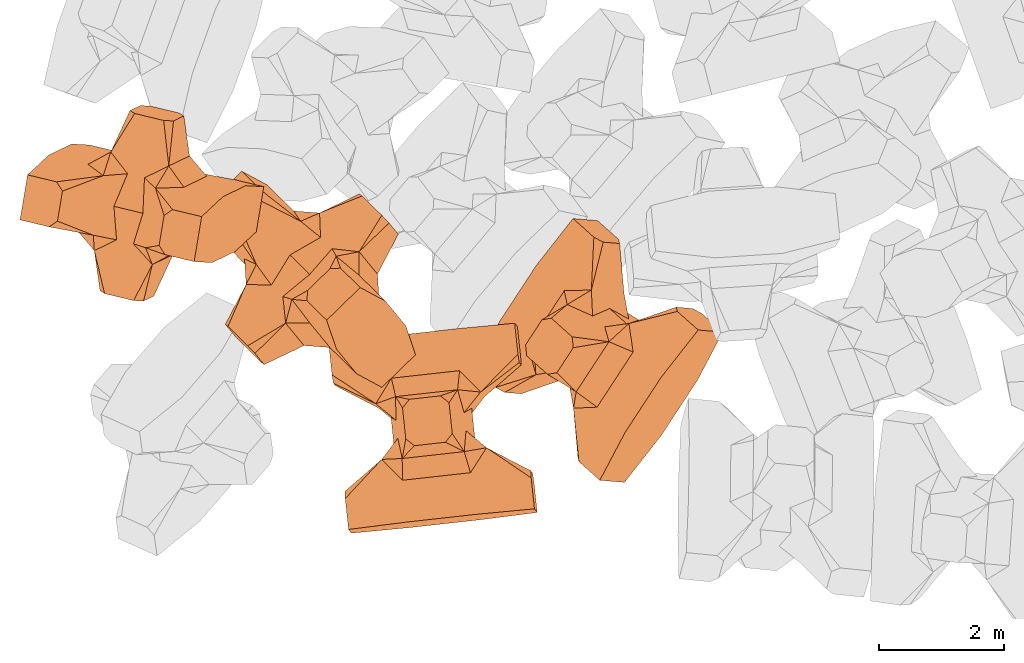
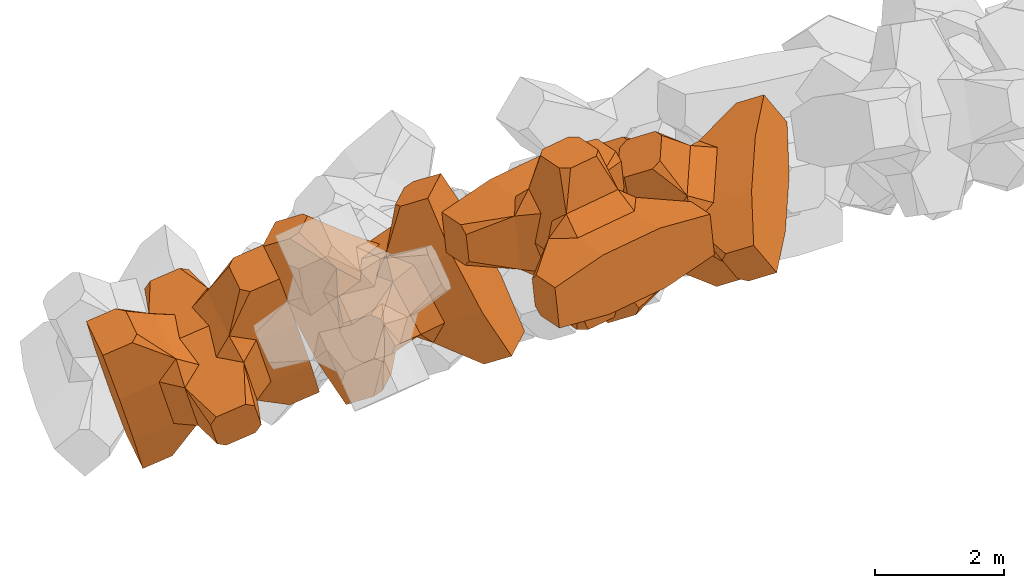
# One storey, part 11 of 17: 4 civil elements.
"""IFC4 building model written with IfcOpenShell, lengths in metres."""

import ifcopenshell
import ifcopenshell.guid

model = None  # the IFC model being written
_history = None  # IfcOwnerHistory: only IFC2X3 demands one
_inside = {}  # id of a spatial element -> (the spatial element, [elements in it])
_under = {}  # id of a project, library or spatial element -> (it, [spatial elements below it])
_declared = {}  # id of a project -> (the project, [libraries it declares])
_typed = {}  # id of a type object -> (the type object, [elements of that type])
_made_of = {}  # id of a material, layer set ... -> (it, [elements and type objects made of it])


def new_model(schema):
    """Start an empty IFC model of exactly this schema.

    Asked for "IFC4X3", IfcOpenShell would pick the latest addendum, in which some entities
    have other attributes; the version numbers below select the first issue.
    IFC2X3 requires an IfcOwnerHistory on every rooted entity: one is made here for all.
    """
    global model, _history
    if schema == "IFC4X3":
        model = ifcopenshell.file(schema_version=(4, 3, 0, 0))
    else:
        model = ifcopenshell.file(schema=schema)
    _inside.clear()
    _under.clear()
    _declared.clear()
    _typed.clear()
    _made_of.clear()
    _history = None
    if model.schema == "IFC2X3":
        org = make("IfcOrganization", Name="unknown")
        user = make(
            "IfcPersonAndOrganization",
            ThePerson=make("IfcPerson", FamilyName="unknown"),
            TheOrganization=org,
        )
        app = make(
            "IfcApplication",
            ApplicationDeveloper=org,
            Version="unknown",
            ApplicationFullName="unknown",
            ApplicationIdentifier="unknown",
        )
        _history = make(
            "IfcOwnerHistory",
            OwningUser=user,
            OwningApplication=app,
            ChangeAction="ADDED",
            CreationDate=0,
        )
    return model


def make(cls, **values):
    """One entity of the class cls with the attributes given. An attribute that is None is left unset."""
    return model.create_entity(
        cls, **{name: value for name, value in values.items() if value is not None}
    )


def entity(cls, *values):
    """Any entity or typed value of the class cls, its attributes in the order of the schema. None: left unset."""
    e = model.create_entity(cls)
    for i, value in enumerate(values):
        if value is not None:
            e[i] = value
    return e


def rooted(cls, **values):
    """An entity with a GlobalId (a new one), such as an element, a storey or a relation."""
    return make(cls, GlobalId=ifcopenshell.guid.new(), OwnerHistory=_history, **values)


def si_unit(unit_type, name, prefix=None):
    """IfcSIUnit, for example si_unit("LENGTHUNIT", "METRE", prefix="MILLI")."""
    return make("IfcSIUnit", UnitType=unit_type, Prefix=prefix, Name=name)


def converted_unit(unit_type, name, factor, base, dimensions=None, offset=None):
    """IfcConversionBasedUnit, such as the inch: factor (a typed value) times the base unit."""
    return make(
        "IfcConversionBasedUnit"
        if offset is None
        else "IfcConversionBasedUnitWithOffset",
        ConversionOffset=offset,
        Dimensions=None
        if dimensions is None
        else entity("IfcDimensionalExponents", *dimensions),
        UnitType=unit_type,
        Name=name,
        ConversionFactor=make(
            "IfcMeasureWithUnit", ValueComponent=factor, UnitComponent=base
        ),
    )


def assignment(units):
    """IfcUnitAssignment: the units of a project."""
    return None if units is None else make("IfcUnitAssignment", Units=units)


def point(xyz):
    """IfcCartesianPoint."""
    return None if xyz is None else make("IfcCartesianPoint", Coordinates=xyz)


def direction(xyz):
    """IfcDirection."""
    return None if xyz is None else make("IfcDirection", DirectionRatios=xyz)


def frame(location, z_axis=None, x_axis=None):
    """IfcAxis2Placement3D, a coordinate frame: its origin and axes. An axis left out is left unset."""
    return make(
        "IfcAxis2Placement3D",
        Location=point(location),
        Axis=direction(z_axis),
        RefDirection=direction(x_axis),
    )


def frame_2d(location, x_axis=None):
    """IfcAxis2Placement2D, a coordinate frame in the plane: its origin and x axis."""
    return make(
        "IfcAxis2Placement2D", Location=point(location), RefDirection=direction(x_axis)
    )


def origin_with_axes():
    """The frame at (0, 0, 0) with the z axis (0, 0, 1) and the x axis (1, 0, 0) written out."""
    return frame((0.0, 0.0, 0.0), z_axis=(0.0, 0.0, 1.0), x_axis=(1.0, 0.0, 0.0))


def origin_2d_with_axis():
    """The frame at (0, 0) in the plane with the x axis (1, 0) written out."""
    return frame_2d((0.0, 0.0), x_axis=(1.0, 0.0))


def place(relative_to, where):
    """IfcLocalPlacement: puts the frame where relative to a parent placement (None: the world)."""
    return make(
        "IfcLocalPlacement", PlacementRelTo=relative_to, RelativePlacement=where
    )


def context(
    kind, dimensions, precision=None, world=None, true_north=None, identifier=None
):
    """IfcGeometricRepresentationContext, for example the 3D "Model" context."""
    return make(
        "IfcGeometricRepresentationContext",
        ContextIdentifier=identifier,
        ContextType=kind,
        CoordinateSpaceDimension=dimensions,
        Precision=precision,
        WorldCoordinateSystem=world,
        TrueNorth=true_north,
    )


def subcontext(parent, identifier, kind, view, scale=None):
    """IfcGeometricRepresentationSubContext, for example "Body" below "Model"."""
    return make(
        "IfcGeometricRepresentationSubContext",
        ContextIdentifier=identifier,
        ContextType=kind,
        ParentContext=parent,
        TargetScale=scale,
        TargetView=view,
    )


def project(units=None, contexts=None):
    """IfcProject with its units and contexts."""
    return rooted(
        "IfcProject",
        Name="project",
        RepresentationContexts=contexts,
        UnitsInContext=assignment(units),
    )


def spatial(cls, under=None, at=None, **own):
    """A site, building, storey or space (cls), placed at a placement, below another one or the project."""
    s = rooted(cls, ObjectPlacement=at, **own)
    if under is not None:
        _under.setdefault(under.id(), (under, []))[1].append(s)
    return s


def point_list(points):
    """IfcCartesianPointList2D or 3D."""
    cls = (
        "IfcCartesianPointList2D" if len(points[0]) == 2 else "IfcCartesianPointList3D"
    )
    return make(cls, CoordList=points)


def polygons(points, faces, closed=None, point_numbers=None):
    """IfcPolygonalFaceSet: a face is its outer loop, then its inner loops; points numbered from 1."""
    made = []
    for loops in faces:
        if len(loops) == 1:
            made.append(make("IfcIndexedPolygonalFace", CoordIndex=loops[0]))
        else:
            made.append(
                make(
                    "IfcIndexedPolygonalFaceWithVoids",
                    CoordIndex=loops[0],
                    InnerCoordIndices=loops[1:],
                )
            )
    return make(
        "IfcPolygonalFaceSet",
        Coordinates=point_list(points),
        Closed=closed,
        Faces=made,
        PnIndex=point_numbers,
    )


def shape(context_of_items, identifier, shape_type, items):
    """IfcShapeRepresentation: the items that make up one representation, for example the "Body"."""
    return make(
        "IfcShapeRepresentation",
        ContextOfItems=context_of_items,
        RepresentationIdentifier=identifier,
        RepresentationType=shape_type,
        Items=items,
    )


def made_of(thing, what):
    """Note that an element or type object is made of a material, layer set ...; save() writes the relation."""
    if what is not None:
        _made_of.setdefault(what.id(), (what, []))[1].append(thing)
    return thing


def element(
    cls,
    number,
    at=None,
    inside=None,
    cuts=None,
    type_object=None,
    material=None,
    context=None,
    identifier="Body",
    shape_type=None,
    held_by="IfcProductDefinitionShape",
    body=None,
    shapes=None,
    **own,
):
    """One element of the class cls, such as IfcWall. Its Tag is "e" and its number.

    at: its placement. inside: the storey or other place that contains it. cuts: it is an
    opening in that element (IfcRelVoidsElement). A single representation is given by context,
    identifier, shape_type and body (its items); several are given by shapes. held_by: the class
    of the entity that holds the representations. save() writes the other relations.
    """
    e = rooted(cls, Tag="e%d" % number, ObjectPlacement=at, **own)
    if body is not None:
        shapes = [shape(context, identifier, shape_type, body)]
    if shapes is not None:
        e.Representation = make(held_by, Representations=shapes)
    if inside is not None:
        _inside.setdefault(inside.id(), (inside, []))[1].append(e)
    if cuts is not None:
        rooted(
            "IfcRelVoidsElement", RelatingBuildingElement=cuts, RelatedOpeningElement=e
        )
    if type_object is not None:
        _typed.setdefault(type_object.id(), (type_object, []))[1].append(e)
    return made_of(e, material)


def aggregate(whole, parts):
    """IfcRelAggregates: a whole, such as a stair, and the parts it consists of."""
    return rooted("IfcRelAggregates", RelatingObject=whole, RelatedObjects=parts)


def save(model, path):
    """Write the relations noted so far, then the file.

    IfcRelAggregates (storeys below a building ...), IfcRelContainedInSpatialStructure (elements
    in a storey), IfcRelDefinesByType, IfcRelAssociatesMaterial and IfcRelDeclares: one each for
    every whole, place, type object, material and project.
    """
    for whole, parts in _under.values():
        aggregate(whole, parts)
    for where, things in _inside.values():
        rooted(
            "IfcRelContainedInSpatialStructure",
            RelatedElements=things,
            RelatingStructure=where,
        )
    for kind, things in _typed.values():
        rooted("IfcRelDefinesByType", RelatedObjects=things, RelatingType=kind)
    for what, things in _made_of.values():
        rooted("IfcRelAssociatesMaterial", RelatedObjects=things, RelatingMaterial=what)
    for by, libraries in _declared.values():
        rooted("IfcRelDeclares", RelatingContext=by, RelatedDefinitions=libraries)
    model.write(path)


model = new_model("IFC4")

# Units and contexts
model_context = context("Model", 3, precision=1e-05, world=origin_with_axes())
plan_context = context("Plan", 2, precision=1e-05, world=origin_2d_with_axis())
body_context = subcontext(model_context, "Body", "Model", "MODEL_VIEW")
ifc_project = project(units=[si_unit("VOLUMEUNIT", "CUBIC_METRE"), si_unit("LENGTHUNIT", "METRE"), converted_unit("PLANEANGLEUNIT", "degree", entity("IfcReal", 0.0174532925199433), si_unit("PLANEANGLEUNIT", "RADIAN"), dimensions=[0, 0, 0, 0, 0, 0, 0]), si_unit("AREAUNIT", "SQUARE_METRE")], contexts=[model_context, plan_context])

# Site, building, storey
site_placement = place(None, origin_with_axes())
site = spatial("IfcSite", under=ifc_project, at=site_placement)
building_placement = place(site_placement, origin_with_axes())
building = spatial("IfcBuilding", under=site, at=building_placement, Name="Building")
storey_placement = place(building_placement, origin_with_axes())
storey = spatial("IfcBuildingStorey", under=building, at=storey_placement, Name="Storey")

# Civil elements
civil_element_1_placement = place(storey_placement, frame((0.976797163486481, 17.1496696472168, 4.11775398254395), z_axis=(-0.160271142377573, -0.961702969398916, -0.222352332054997), x_axis=(0.332126405618707, 0.159588275803917, -0.929636290662499)))
element("IfcCivilElement", 1, at=civil_element_1_placement, inside=storey, ObjectType="IfcCivilElementType", context=body_context, shape_type="Tessellation", body=[
    polygons([(0.500000178813934, 0.5, 0.821428835391998), (0.374999850988388, 0.249999925494194, 1.50000035762787), (0.550000071525574, 0.145680606365204, 0.550000190734863), (0.374999850988388, -0.25, 1.50000035762787), (0.651315867900848, -0.25, 1.45970574294552e-07), (0.651315867900848, 0.249999925494194, 1.45970574294552e-07), (0.550000071525574, -0.14568068087101, 0.550000190734863), (0.500000178813934, -0.5, 0.821428835391998), (-0.250000029802322, 0.374999761581421, 1.50000035762787), (0.249999985098839, 0.374999761581421, 1.50000035762787), (-0.500000059604645, 0.5, 0.821428835391998), (-0.550000071525574, 0.824999928474426, 0.550000190734863), (0.550000071525574, 0.824999928474426, 0.550000190734863), (-0.550000071525574, 1.49999988079071, 0.550000190734863), (0.550000071525574, 1.49999988079071, 0.550000190734863), (-0.250000029802322, -0.374999970197678, 1.50000035762787), (0.249999985098839, -0.374999970197678, 1.50000035762787), (-0.375, -0.25, 1.50000035762787), (-0.375, 0.249999925494194, 1.50000035762787), (1.50000023841858, 0.874999761581421, -0.249999865889549), (1.50000023841858, 0.874999761581421, 0.250000149011612), (0.845557630062103, 0.449999868869781, -0.495555222034454), (0.845557630062103, 0.449999868869781, 0.495555222034454), (1.50000023841858, 1.49999988079071, -0.374999850988388), (1.50000023841858, 1.49999988079071, 0.375), (1.50000023841858, 0.99999988079071, -0.374999850988388), (1.50000023841858, 0.99999988079071, 0.375), (-1.50000023841858, 1.49999988079071, -0.374999850988388), (-1.50000023841858, 1.49999988079071, 0.375), (-0.550000071525574, 1.49999988079071, -0.549999892711639), (0.550000071525574, 1.49999988079071, -0.549999892711639), (0.550000071525574, 0.145680606365204, -0.549999892711639), (-0.500000059604645, -0.5, 0.821428835391998), (-0.550000071525574, -0.14568068087101, 0.550000190734863), (-0.651315867900848, 0.249999925494194, 1.45970574294552e-07), (-0.651315867900848, -0.25, 1.45970574294552e-07), (-0.550000071525574, 0.145680606365204, 0.550000190734863), (-1.50000023841858, 0.874999761581421, 0.250000149011612), (-1.50000023841858, 0.874999761581421, -0.249999865889549), (-0.845557451248169, 0.449999868869781, 0.495555222034454), (-0.845557451248169, 0.449999868869781, -0.495555222034454), (-1.50000023841858, 0.99999988079071, 0.375), (-1.50000023841858, 0.99999988079071, -0.374999850988388), (-0.550000071525574, 0.145680606365204, -0.549999892711639), (0.550000071525574, -0.825000047683716, 0.550000190734863), (-0.550000071525574, -0.825000047683716, 0.550000190734863), (0.550000071525574, -1.49999988079071, 0.550000190734863), (-0.550000071525574, -1.49999988079071, 0.550000190734863), (1.50000023841858, -0.875, 0.250000149011612), (1.50000023841858, -0.875, -0.249999865889549), (0.845557630062103, -0.450000077486038, 0.495555222034454), (0.845557630062103, -0.450000077486038, -0.495555222034454), (1.50000023841858, -1.49999988079071, 0.375), (1.50000023841858, -1.49999988079071, -0.374999850988388), (1.50000023841858, -1.0, 0.375), (1.50000023841858, -1.0, -0.374999850988388), (0.550000071525574, -1.49999988079071, -0.549999892711639), (-0.550000071525574, -1.49999988079071, -0.549999892711639), (-1.50000023841858, -1.49999988079071, -0.374999850988388), (-1.50000023841858, -1.49999988079071, 0.375), (0.550000071525574, -0.14568068087101, -0.549999892711639), (-1.50000023841858, -0.875, -0.249999865889549), (-1.50000023841858, -0.875, 0.250000149011612), (-0.845557451248169, -0.450000077486038, -0.495555222034454), (-0.845557451248169, -0.450000077486038, 0.495555222034454), (-1.50000023841858, -1.0, -0.374999850988388), (-1.50000023841858, -1.0, 0.375), (-0.550000071525574, -0.14568068087101, -0.549999892711639), (0.500000178813934, -0.5, -0.821428596973419), (0.374999850988388, -0.25, -1.5), (0.374999850988388, 0.249999925494194, -1.5), (0.500000178813934, 0.5, -0.821428596973419), (0.249999985098839, 0.374999761581421, -1.5), (-0.250000029802322, 0.374999761581421, -1.5), (-0.500000059604645, 0.5, -0.821428596973419), (0.550000071525574, 0.824999928474426, -0.549999892711639), (-0.550000071525574, 0.824999928474426, -0.549999892711639), (0.249999985098839, -0.374999970197678, -1.5), (-0.250000029802322, -0.374999970197678, -1.5), (-0.375, -0.25, -1.5), (-0.375, 0.249999925494194, -1.5), (-0.500000059604645, -0.5, -0.821428596973419), (-0.550000071525574, -0.825000047683716, -0.549999892711639), (0.550000071525574, -0.825000047683716, -0.549999892711639)], [[[1, 2, 3]], [[3, 2, 4]], [[5, 6, 7]], [[7, 6, 3]], [[7, 3, 8]], [[8, 3, 4]], [[9, 10, 11]], [[11, 10, 1]], [[12, 13, 14]], [[14, 13, 15]], [[16, 17, 18]], [[18, 17, 4]], [[18, 4, 19]], [[19, 4, 2]], [[19, 2, 9]], [[9, 2, 10]], [[20, 21, 22]], [[22, 21, 23]], [[24, 25, 26]], [[26, 25, 27]], [[26, 27, 20]], [[20, 27, 21]], [[23, 27, 13]], [[13, 27, 25]], [[13, 25, 15]], [[28, 29, 30]], [[30, 29, 14]], [[30, 14, 31]], [[31, 14, 15]], [[31, 15, 24]], [[24, 15, 25]], [[21, 27, 23]], [[2, 1, 10]], [[13, 12, 1]], [[1, 12, 11]], [[13, 1, 23]], [[32, 22, 6]], [[6, 22, 23]], [[6, 23, 3]], [[3, 23, 1]], [[33, 18, 34]], [[34, 18, 19]], [[35, 36, 37]], [[37, 36, 34]], [[37, 34, 11]], [[11, 34, 19]], [[38, 39, 40]], [[40, 39, 41]], [[29, 28, 42]], [[42, 28, 43]], [[42, 43, 38]], [[38, 43, 39]], [[14, 29, 12]], [[12, 29, 42]], [[12, 42, 40]], [[40, 42, 38]], [[9, 11, 19]], [[40, 11, 12]], [[37, 40, 35]], [[35, 40, 41]], [[35, 41, 44]], [[11, 40, 37]], [[17, 16, 8]], [[8, 16, 33]], [[45, 46, 47]], [[47, 46, 48]], [[49, 50, 51]], [[51, 50, 52]], [[53, 54, 55]], [[55, 54, 56]], [[55, 56, 49]], [[49, 56, 50]], [[47, 53, 45]], [[45, 53, 55]], [[45, 55, 51]], [[54, 53, 57]], [[57, 53, 47]], [[57, 47, 58]], [[58, 47, 48]], [[58, 48, 59]], [[59, 48, 60]], [[51, 55, 49]], [[17, 8, 4]], [[46, 45, 33]], [[33, 45, 8]], [[51, 8, 45]], [[7, 51, 5]], [[5, 51, 52]], [[5, 52, 61]], [[8, 51, 7]], [[62, 63, 64]], [[64, 63, 65]], [[59, 60, 66]], [[66, 60, 67]], [[66, 67, 62]], [[62, 67, 63]], [[65, 67, 46]], [[46, 67, 60]], [[46, 60, 48]], [[63, 67, 65]], [[18, 33, 16]], [[46, 33, 65]], [[68, 64, 36]], [[36, 64, 65]], [[36, 65, 34]], [[34, 65, 33]], [[69, 70, 61]], [[61, 70, 71]], [[6, 5, 32]], [[32, 5, 61]], [[32, 61, 72]], [[72, 61, 71]], [[73, 74, 72]], [[72, 74, 75]], [[76, 77, 31]], [[31, 77, 30]], [[78, 79, 70]], [[70, 79, 80]], [[70, 80, 71]], [[71, 80, 81]], [[71, 81, 73]], [[73, 81, 74]], [[31, 24, 76]], [[76, 24, 26]], [[76, 26, 22]], [[22, 26, 20]], [[73, 72, 71]], [[77, 76, 75]], [[75, 76, 72]], [[22, 72, 76]], [[72, 22, 32]], [[75, 81, 44]], [[44, 81, 80]], [[36, 35, 68]], [[68, 35, 44]], [[68, 44, 82]], [[82, 44, 80]], [[41, 43, 77]], [[77, 43, 28]], [[77, 28, 30]], [[39, 43, 41]], [[81, 75, 74]], [[77, 75, 41]], [[44, 41, 75]], [[79, 78, 82]], [[82, 78, 69]], [[83, 84, 58]], [[58, 84, 57]], [[52, 56, 84]], [[84, 56, 54]], [[84, 54, 57]], [[50, 56, 52]], [[70, 69, 78]], [[84, 83, 69]], [[69, 83, 82]], [[84, 69, 52]], [[61, 52, 69]], [[58, 59, 83]], [[83, 59, 66]], [[83, 66, 64]], [[64, 66, 62]], [[79, 82, 80]], [[64, 82, 83]], [[82, 64, 68]]], closed=True),
])
civil_element_2_placement = place(storey_placement, frame((3.69786596298218, 15.9331550598145, 5.18915796279907), z_axis=(-0.716127885040734, -0.696584713768642, 0.0439384661878981), x_axis=(0.294663222145376, -0.35879656855293, -0.885685388786305)))
element("IfcCivilElement", 2, at=civil_element_2_placement, inside=storey, ObjectType="IfcCivilElementType", context=body_context, shape_type="Tessellation", body=[
    polygons([(0.50000011920929, 0.500000059604645, 0.821428835391998), (0.374999821186066, 0.249999940395355, 1.50000035762787), (0.550000011920929, 0.145680621266365, 0.550000190734863), (0.374999821186066, -0.250000029802322, 1.50000035762787), (0.651315808296204, -0.250000029802322, 1.45970574294552e-07), (0.651315808296204, 0.249999940395355, 1.45970574294552e-07), (0.550000011920929, -0.145680695772171, 0.550000190734863), (0.50000011920929, -0.500000059604645, 0.821428835391998), (-0.25, 0.374999791383743, 1.50000035762787), (0.249999970197678, 0.374999791383743, 1.50000035762787), (-0.500000059604645, 0.500000059604645, 0.821428835391998), (-0.550000011920929, 0.824999988079071, 0.550000190734863), (0.550000011920929, 0.824999988079071, 0.550000190734863), (-0.550000011920929, 1.5, 0.550000190734863), (0.550000011920929, 1.5, 0.550000190734863), (-0.25, -0.375, 1.50000035762787), (0.249999970197678, -0.375, 1.50000035762787), (-0.374999970197678, -0.250000029802322, 1.50000035762787), (-0.374999970197678, 0.249999940395355, 1.50000035762787), (1.5, 0.87499988079071, -0.249999865889549), (1.5, 0.87499988079071, 0.250000149011612), (0.845557510852814, 0.449999898672104, -0.495555222034454), (0.845557510852814, 0.449999898672104, 0.495555222034454), (1.5, 1.5, -0.374999850988388), (1.5, 1.5, 0.375), (1.5, 1.0, -0.374999850988388), (1.5, 1.0, 0.375), (-1.5, 1.5, -0.374999850988388), (-1.5, 1.5, 0.375), (-0.550000011920929, 1.5, -0.549999892711639), (0.550000011920929, 1.5, -0.549999892711639), (0.550000011920929, 0.145680621266365, -0.549999892711639), (-0.500000059604645, -0.500000059604645, 0.821428835391998), (-0.550000011920929, -0.145680695772171, 0.550000190734863), (-0.651315808296204, 0.249999940395355, 1.45970574294552e-07), (-0.651315808296204, -0.250000029802322, 1.45970574294552e-07), (-0.550000011920929, 0.145680621266365, 0.550000190734863), (-1.5, 0.87499988079071, 0.250000149011612), (-1.5, 0.87499988079071, -0.249999865889549), (-0.845557391643524, 0.449999898672104, 0.495555222034454), (-0.845557391643524, 0.449999898672104, -0.495555222034454), (-1.5, 1.0, 0.375), (-1.5, 1.0, -0.374999850988388), (-0.550000011920929, 0.145680621266365, -0.549999892711639), (0.550000011920929, -0.825000107288361, 0.550000190734863), (-0.550000011920929, -0.825000107288361, 0.550000190734863), (0.550000011920929, -1.5, 0.550000190734863), (-0.550000011920929, -1.5, 0.550000190734863), (1.5, -0.875000059604645, 0.250000149011612), (1.5, -0.875000059604645, -0.249999865889549), (0.845557510852814, -0.450000137090683, 0.495555222034454), (0.845557510852814, -0.450000137090683, -0.495555222034454), (1.5, -1.5, 0.375), (1.5, -1.5, -0.374999850988388), (1.5, -1.00000011920929, 0.375), (1.5, -1.00000011920929, -0.374999850988388), (0.550000011920929, -1.5, -0.549999892711639), (-0.550000011920929, -1.5, -0.549999892711639), (-1.5, -1.5, -0.374999850988388), (-1.5, -1.5, 0.375), (0.550000011920929, -0.145680695772171, -0.549999892711639), (-1.5, -0.875000059604645, -0.249999865889549), (-1.5, -0.875000059604645, 0.250000149011612), (-0.845557391643524, -0.450000137090683, -0.495555222034454), (-0.845557391643524, -0.450000137090683, 0.495555222034454), (-1.5, -1.00000011920929, -0.374999850988388), (-1.5, -1.00000011920929, 0.375), (-0.550000011920929, -0.145680695772171, -0.549999892711639), (0.50000011920929, -0.500000059604645, -0.821428596973419), (0.374999821186066, -0.250000029802322, -1.5), (0.374999821186066, 0.249999940395355, -1.5), (0.50000011920929, 0.500000059604645, -0.821428596973419), (0.249999970197678, 0.374999791383743, -1.5), (-0.25, 0.374999791383743, -1.5), (-0.500000059604645, 0.500000059604645, -0.821428596973419), (0.550000011920929, 0.824999988079071, -0.549999892711639), (-0.550000011920929, 0.824999988079071, -0.549999892711639), (0.249999970197678, -0.375, -1.5), (-0.25, -0.375, -1.5), (-0.374999970197678, -0.250000029802322, -1.5), (-0.374999970197678, 0.249999940395355, -1.5), (-0.500000059604645, -0.500000059604645, -0.821428596973419), (-0.550000011920929, -0.825000107288361, -0.549999892711639), (0.550000011920929, -0.825000107288361, -0.549999892711639)], [[[1, 2, 3]], [[3, 2, 4]], [[5, 6, 7]], [[7, 6, 3]], [[7, 3, 8]], [[8, 3, 4]], [[9, 10, 11]], [[11, 10, 1]], [[12, 13, 14]], [[14, 13, 15]], [[16, 17, 18]], [[18, 17, 4]], [[18, 4, 19]], [[19, 4, 2]], [[19, 2, 9]], [[9, 2, 10]], [[20, 21, 22]], [[22, 21, 23]], [[24, 25, 26]], [[26, 25, 27]], [[26, 27, 20]], [[20, 27, 21]], [[23, 27, 13]], [[13, 27, 25]], [[13, 25, 15]], [[28, 29, 30]], [[30, 29, 14]], [[30, 14, 31]], [[31, 14, 15]], [[31, 15, 24]], [[24, 15, 25]], [[21, 27, 23]], [[2, 1, 10]], [[13, 12, 1]], [[1, 12, 11]], [[13, 1, 23]], [[32, 22, 6]], [[6, 22, 23]], [[6, 23, 3]], [[3, 23, 1]], [[33, 18, 34]], [[34, 18, 19]], [[35, 36, 37]], [[37, 36, 34]], [[37, 34, 11]], [[11, 34, 19]], [[38, 39, 40]], [[40, 39, 41]], [[29, 28, 42]], [[42, 28, 43]], [[42, 43, 38]], [[38, 43, 39]], [[14, 29, 12]], [[12, 29, 42]], [[12, 42, 40]], [[40, 42, 38]], [[9, 11, 19]], [[40, 11, 12]], [[37, 40, 35]], [[35, 40, 41]], [[35, 41, 44]], [[11, 40, 37]], [[17, 16, 8]], [[8, 16, 33]], [[45, 46, 47]], [[47, 46, 48]], [[49, 50, 51]], [[51, 50, 52]], [[53, 54, 55]], [[55, 54, 56]], [[55, 56, 49]], [[49, 56, 50]], [[47, 53, 45]], [[45, 53, 55]], [[45, 55, 51]], [[54, 53, 57]], [[57, 53, 47]], [[57, 47, 58]], [[58, 47, 48]], [[58, 48, 59]], [[59, 48, 60]], [[51, 55, 49]], [[17, 8, 4]], [[46, 45, 33]], [[33, 45, 8]], [[51, 8, 45]], [[7, 51, 5]], [[5, 51, 52]], [[5, 52, 61]], [[8, 51, 7]], [[62, 63, 64]], [[64, 63, 65]], [[59, 60, 66]], [[66, 60, 67]], [[66, 67, 62]], [[62, 67, 63]], [[65, 67, 46]], [[46, 67, 60]], [[46, 60, 48]], [[63, 67, 65]], [[18, 33, 16]], [[46, 33, 65]], [[68, 64, 36]], [[36, 64, 65]], [[36, 65, 34]], [[34, 65, 33]], [[69, 70, 61]], [[61, 70, 71]], [[6, 5, 32]], [[32, 5, 61]], [[32, 61, 72]], [[72, 61, 71]], [[73, 74, 72]], [[72, 74, 75]], [[76, 77, 31]], [[31, 77, 30]], [[78, 79, 70]], [[70, 79, 80]], [[70, 80, 71]], [[71, 80, 81]], [[71, 81, 73]], [[73, 81, 74]], [[31, 24, 76]], [[76, 24, 26]], [[76, 26, 22]], [[22, 26, 20]], [[73, 72, 71]], [[77, 76, 75]], [[75, 76, 72]], [[22, 72, 76]], [[72, 22, 32]], [[75, 81, 44]], [[44, 81, 80]], [[36, 35, 68]], [[68, 35, 44]], [[68, 44, 82]], [[82, 44, 80]], [[41, 43, 77]], [[77, 43, 28]], [[77, 28, 30]], [[39, 43, 41]], [[81, 75, 74]], [[77, 75, 41]], [[44, 41, 75]], [[79, 78, 82]], [[82, 78, 69]], [[83, 84, 58]], [[58, 84, 57]], [[52, 56, 84]], [[84, 56, 54]], [[84, 54, 57]], [[50, 56, 52]], [[70, 69, 78]], [[84, 83, 69]], [[69, 83, 82]], [[84, 69, 52]], [[61, 52, 69]], [[58, 59, 83]], [[83, 59, 66]], [[83, 66, 64]], [[64, 66, 62]], [[79, 82, 80]], [[64, 82, 83]], [[82, 64, 68]]], closed=True),
])
civil_element_3_placement = place(storey_placement, frame((8.29291915893555, 14.7925434112549, 5.79320192337036), z_axis=(0.526510830352066, -0.0448656301970918, -0.848983757647339), x_axis=(0.525248113273427, 0.802392844936422, 0.28333750527867)))
element("IfcCivilElement", 3, at=civil_element_3_placement, inside=storey, ObjectType="IfcCivilElementType", context=body_context, shape_type="Tessellation", body=[
    polygons([(0.50000011920929, 0.500000059604645, 0.821428716182709), (0.374999821186066, 0.249999940395355, 1.50000023841858), (0.550000011920929, 0.145680621266365, 0.550000131130219), (0.374999821186066, -0.250000029802322, 1.50000023841858), (0.651315808296204, -0.250000029802322, 1.45970560083697e-07), (0.651315808296204, 0.249999940395355, 1.45970560083697e-07), (0.550000011920929, -0.145680695772171, 0.550000131130219), (0.50000011920929, -0.500000059604645, 0.821428716182709), (-0.25, 0.374999791383743, 1.50000023841858), (0.249999970197678, 0.374999791383743, 1.50000023841858), (-0.500000059604645, 0.500000059604645, 0.821428716182709), (-0.550000011920929, 0.824999988079071, 0.550000131130219), (0.550000011920929, 0.824999988079071, 0.550000131130219), (-0.550000011920929, 1.5, 0.550000131130219), (0.550000011920929, 1.5, 0.550000131130219), (-0.25, -0.375, 1.50000023841858), (0.249999970197678, -0.375, 1.50000023841858), (-0.374999970197678, -0.250000029802322, 1.50000023841858), (-0.374999970197678, 0.249999940395355, 1.50000023841858), (1.5, 0.87499988079071, -0.249999836087227), (1.5, 0.87499988079071, 0.25000011920929), (0.845557510852814, 0.449999898672104, -0.49555516242981), (0.845557510852814, 0.449999898672104, 0.49555516242981), (1.5, 1.5, -0.374999821186066), (1.5, 1.5, 0.374999970197678), (1.5, 1.0, -0.374999821186066), (1.5, 1.0, 0.374999970197678), (-1.5, 1.5, -0.374999821186066), (-1.5, 1.5, 0.374999970197678), (-0.550000011920929, 1.5, -0.549999833106995), (0.550000011920929, 1.5, -0.549999833106995), (0.550000011920929, 0.145680621266365, -0.549999833106995), (-0.500000059604645, -0.500000059604645, 0.821428716182709), (-0.550000011920929, -0.145680695772171, 0.550000131130219), (-0.651315808296204, 0.249999940395355, 1.45970560083697e-07), (-0.651315808296204, -0.250000029802322, 1.45970560083697e-07), (-0.550000011920929, 0.145680621266365, 0.550000131130219), (-1.5, 0.87499988079071, 0.25000011920929), (-1.5, 0.87499988079071, -0.249999836087227), (-0.845557391643524, 0.449999898672104, 0.49555516242981), (-0.845557391643524, 0.449999898672104, -0.49555516242981), (-1.5, 1.0, 0.374999970197678), (-1.5, 1.0, -0.374999821186066), (-0.550000011920929, 0.145680621266365, -0.549999833106995), (0.550000011920929, -0.825000107288361, 0.550000131130219), (-0.550000011920929, -0.825000107288361, 0.550000131130219), (0.550000011920929, -1.5, 0.550000131130219), (-0.550000011920929, -1.5, 0.550000131130219), (1.5, -0.875000059604645, 0.25000011920929), (1.5, -0.875000059604645, -0.249999836087227), (0.845557510852814, -0.450000137090683, 0.49555516242981), (0.845557510852814, -0.450000137090683, -0.49555516242981), (1.5, -1.5, 0.374999970197678), (1.5, -1.5, -0.374999821186066), (1.5, -1.00000011920929, 0.374999970197678), (1.5, -1.00000011920929, -0.374999821186066), (0.550000011920929, -1.5, -0.549999833106995), (-0.550000011920929, -1.5, -0.549999833106995), (-1.5, -1.5, -0.374999821186066), (-1.5, -1.5, 0.374999970197678), (0.550000011920929, -0.145680695772171, -0.549999833106995), (-1.5, -0.875000059604645, -0.249999836087227), (-1.5, -0.875000059604645, 0.25000011920929), (-0.845557391643524, -0.450000137090683, -0.49555516242981), (-0.845557391643524, -0.450000137090683, 0.49555516242981), (-1.5, -1.00000011920929, -0.374999821186066), (-1.5, -1.00000011920929, 0.374999970197678), (-0.550000011920929, -0.145680695772171, -0.549999833106995), (0.50000011920929, -0.500000059604645, -0.821428537368774), (0.374999821186066, -0.250000029802322, -1.49999988079071), (0.374999821186066, 0.249999940395355, -1.49999988079071), (0.50000011920929, 0.500000059604645, -0.821428537368774), (0.249999970197678, 0.374999791383743, -1.49999988079071), (-0.25, 0.374999791383743, -1.49999988079071), (-0.500000059604645, 0.500000059604645, -0.821428537368774), (0.550000011920929, 0.824999988079071, -0.549999833106995), (-0.550000011920929, 0.824999988079071, -0.549999833106995), (0.249999970197678, -0.375, -1.49999988079071), (-0.25, -0.375, -1.49999988079071), (-0.374999970197678, -0.250000029802322, -1.49999988079071), (-0.374999970197678, 0.249999940395355, -1.49999988079071), (-0.500000059604645, -0.500000059604645, -0.821428537368774), (-0.550000011920929, -0.825000107288361, -0.549999833106995), (0.550000011920929, -0.825000107288361, -0.549999833106995)], [[[1, 2, 3]], [[3, 2, 4]], [[5, 6, 7]], [[7, 6, 3]], [[7, 3, 8]], [[8, 3, 4]], [[9, 10, 11]], [[11, 10, 1]], [[12, 13, 14]], [[14, 13, 15]], [[16, 17, 18]], [[18, 17, 4]], [[18, 4, 19]], [[19, 4, 2]], [[19, 2, 9]], [[9, 2, 10]], [[20, 21, 22]], [[22, 21, 23]], [[24, 25, 26]], [[26, 25, 27]], [[26, 27, 20]], [[20, 27, 21]], [[23, 27, 13]], [[13, 27, 25]], [[13, 25, 15]], [[28, 29, 30]], [[30, 29, 14]], [[30, 14, 31]], [[31, 14, 15]], [[31, 15, 24]], [[24, 15, 25]], [[21, 27, 23]], [[2, 1, 10]], [[13, 12, 1]], [[1, 12, 11]], [[13, 1, 23]], [[32, 22, 6]], [[6, 22, 23]], [[6, 23, 3]], [[3, 23, 1]], [[33, 18, 34]], [[34, 18, 19]], [[35, 36, 37]], [[37, 36, 34]], [[37, 34, 11]], [[11, 34, 19]], [[38, 39, 40]], [[40, 39, 41]], [[29, 28, 42]], [[42, 28, 43]], [[42, 43, 38]], [[38, 43, 39]], [[14, 29, 12]], [[12, 29, 42]], [[12, 42, 40]], [[40, 42, 38]], [[9, 11, 19]], [[40, 11, 12]], [[37, 40, 35]], [[35, 40, 41]], [[35, 41, 44]], [[11, 40, 37]], [[17, 16, 8]], [[8, 16, 33]], [[45, 46, 47]], [[47, 46, 48]], [[49, 50, 51]], [[51, 50, 52]], [[53, 54, 55]], [[55, 54, 56]], [[55, 56, 49]], [[49, 56, 50]], [[47, 53, 45]], [[45, 53, 55]], [[45, 55, 51]], [[54, 53, 57]], [[57, 53, 47]], [[57, 47, 58]], [[58, 47, 48]], [[58, 48, 59]], [[59, 48, 60]], [[51, 55, 49]], [[17, 8, 4]], [[46, 45, 33]], [[33, 45, 8]], [[51, 8, 45]], [[7, 51, 5]], [[5, 51, 52]], [[5, 52, 61]], [[8, 51, 7]], [[62, 63, 64]], [[64, 63, 65]], [[59, 60, 66]], [[66, 60, 67]], [[66, 67, 62]], [[62, 67, 63]], [[65, 67, 46]], [[46, 67, 60]], [[46, 60, 48]], [[63, 67, 65]], [[18, 33, 16]], [[46, 33, 65]], [[68, 64, 36]], [[36, 64, 65]], [[36, 65, 34]], [[34, 65, 33]], [[69, 70, 61]], [[61, 70, 71]], [[6, 5, 32]], [[32, 5, 61]], [[32, 61, 72]], [[72, 61, 71]], [[73, 74, 72]], [[72, 74, 75]], [[76, 77, 31]], [[31, 77, 30]], [[78, 79, 70]], [[70, 79, 80]], [[70, 80, 71]], [[71, 80, 81]], [[71, 81, 73]], [[73, 81, 74]], [[31, 24, 76]], [[76, 24, 26]], [[76, 26, 22]], [[22, 26, 20]], [[73, 72, 71]], [[77, 76, 75]], [[75, 76, 72]], [[22, 72, 76]], [[72, 22, 32]], [[75, 81, 44]], [[44, 81, 80]], [[36, 35, 68]], [[68, 35, 44]], [[68, 44, 82]], [[82, 44, 80]], [[41, 43, 77]], [[77, 43, 28]], [[77, 28, 30]], [[39, 43, 41]], [[81, 75, 74]], [[77, 75, 41]], [[44, 41, 75]], [[79, 78, 82]], [[82, 78, 69]], [[83, 84, 58]], [[58, 84, 57]], [[52, 56, 84]], [[84, 56, 54]], [[84, 54, 57]], [[50, 56, 52]], [[70, 69, 78]], [[84, 83, 69]], [[69, 83, 82]], [[84, 69, 52]], [[61, 52, 69]], [[58, 59, 83]], [[83, 59, 66]], [[83, 66, 64]], [[64, 66, 62]], [[79, 82, 80]], [[64, 82, 83]], [[82, 64, 68]]], closed=True),
])
civil_element_4_placement = place(storey_placement, frame((5.63853931427002, 13.5478105545044, 7.0128607749939), z_axis=(-0.05966254555019, 0.0794763620755933, 0.995049691487667), x_axis=(-0.992605090051603, -0.110290281464624, -0.0507068932010607)))
element("IfcCivilElement", 4, at=civil_element_4_placement, inside=storey, ObjectType="IfcCivilElementType", context=body_context, shape_type="Tessellation", body=[
    polygons([(0.500000059604645, 0.49999988079071, 0.821428716182709), (0.374999791383743, 0.249999850988388, 1.50000023841858), (0.549999952316284, 0.145680576562881, 0.550000131130219), (0.374999791383743, -0.249999925494194, 1.50000023841858), (0.651315748691559, -0.249999925494194, 1.45970560083697e-07), (0.651315748691559, 0.249999850988388, 1.45970560083697e-07), (0.549999952316284, -0.145680636167526, 0.550000131130219), (0.500000059604645, -0.49999988079071, 0.821428716182709), (-0.249999970197678, 0.374999642372131, 1.50000023841858), (0.249999940395355, 0.374999642372131, 1.50000023841858), (-0.5, 0.49999988079071, 0.821428716182709), (-0.549999952316284, 0.824999690055847, 0.550000131130219), (0.549999952316284, 0.824999690055847, 0.550000131130219), (-0.549999952316284, 1.49999940395355, 0.550000131130219), (0.549999952316284, 1.49999940395355, 0.550000131130219), (-0.249999970197678, -0.374999850988388, 1.50000023841858), (0.249999940395355, -0.374999850988388, 1.50000023841858), (-0.374999940395355, -0.249999925494194, 1.50000023841858), (-0.374999940395355, 0.249999850988388, 1.50000023841858), (1.49999988079071, 0.874999523162842, -0.249999836087227), (1.49999988079071, 0.874999523162842, 0.25000011920929), (0.845557451248169, 0.44999971985817, -0.49555516242981), (0.845557451248169, 0.44999971985817, 0.49555516242981), (1.49999988079071, 1.49999940395355, -0.374999821186066), (1.49999988079071, 1.49999940395355, 0.374999970197678), (1.49999988079071, 0.999999642372131, -0.374999821186066), (1.49999988079071, 0.999999642372131, 0.374999970197678), (-1.49999988079071, 1.49999940395355, -0.374999821186066), (-1.49999988079071, 1.49999940395355, 0.374999970197678), (-0.549999952316284, 1.49999940395355, -0.549999833106995), (0.549999952316284, 1.49999940395355, -0.549999833106995), (0.549999952316284, 0.145680576562881, -0.549999833106995), (-0.5, -0.49999988079071, 0.821428716182709), (-0.549999952316284, -0.145680636167526, 0.550000131130219), (-0.651315748691559, 0.249999850988388, 1.45970560083697e-07), (-0.651315748691559, -0.249999925494194, 1.45970560083697e-07), (-0.549999952316284, 0.145680576562881, 0.550000131130219), (-1.49999988079071, 0.874999523162842, 0.25000011920929), (-1.49999988079071, 0.874999523162842, -0.249999836087227), (-0.845557332038879, 0.44999971985817, 0.49555516242981), (-0.845557332038879, 0.44999971985817, -0.49555516242981), (-1.49999988079071, 0.999999642372131, 0.374999970197678), (-1.49999988079071, 0.999999642372131, -0.374999821186066), (-0.549999952316284, 0.145680576562881, -0.549999833106995), (0.549999952316284, -0.824999809265137, 0.550000131130219), (-0.549999952316284, -0.824999809265137, 0.550000131130219), (0.549999952316284, -1.49999940395355, 0.550000131130219), (-0.549999952316284, -1.49999940395355, 0.550000131130219), (1.49999988079071, -0.874999761581421, 0.25000011920929), (1.49999988079071, -0.874999761581421, -0.249999836087227), (0.845557451248169, -0.449999958276749, 0.49555516242981), (0.845557451248169, -0.449999958276749, -0.49555516242981), (1.49999988079071, -1.49999940395355, 0.374999970197678), (1.49999988079071, -1.49999940395355, -0.374999821186066), (1.49999988079071, -0.999999761581421, 0.374999970197678), (1.49999988079071, -0.999999761581421, -0.374999821186066), (0.549999952316284, -1.49999940395355, -0.549999833106995), (-0.549999952316284, -1.49999940395355, -0.549999833106995), (-1.49999988079071, -1.49999940395355, -0.374999821186066), (-1.49999988079071, -1.49999940395355, 0.374999970197678), (0.549999952316284, -0.145680636167526, -0.549999833106995), (-1.49999988079071, -0.874999761581421, -0.249999836087227), (-1.49999988079071, -0.874999761581421, 0.25000011920929), (-0.845557332038879, -0.449999958276749, -0.49555516242981), (-0.845557332038879, -0.449999958276749, 0.49555516242981), (-1.49999988079071, -0.999999761581421, -0.374999821186066), (-1.49999988079071, -0.999999761581421, 0.374999970197678), (-0.549999952316284, -0.145680636167526, -0.549999833106995), (0.500000059604645, -0.49999988079071, -0.821428537368774), (0.374999791383743, -0.249999925494194, -1.49999988079071), (0.374999791383743, 0.249999850988388, -1.49999988079071), (0.500000059604645, 0.49999988079071, -0.821428537368774), (0.249999940395355, 0.374999642372131, -1.49999988079071), (-0.249999970197678, 0.374999642372131, -1.49999988079071), (-0.5, 0.49999988079071, -0.821428537368774), (0.549999952316284, 0.824999690055847, -0.549999833106995), (-0.549999952316284, 0.824999690055847, -0.549999833106995), (0.249999940395355, -0.374999850988388, -1.49999988079071), (-0.249999970197678, -0.374999850988388, -1.49999988079071), (-0.374999940395355, -0.249999925494194, -1.49999988079071), (-0.374999940395355, 0.249999850988388, -1.49999988079071), (-0.5, -0.49999988079071, -0.821428537368774), (-0.549999952316284, -0.824999809265137, -0.549999833106995), (0.549999952316284, -0.824999809265137, -0.549999833106995)], [[[1, 2, 3]], [[3, 2, 4]], [[5, 6, 7]], [[7, 6, 3]], [[7, 3, 8]], [[8, 3, 4]], [[9, 10, 11]], [[11, 10, 1]], [[12, 13, 14]], [[14, 13, 15]], [[16, 17, 18]], [[18, 17, 4]], [[18, 4, 19]], [[19, 4, 2]], [[19, 2, 9]], [[9, 2, 10]], [[20, 21, 22]], [[22, 21, 23]], [[24, 25, 26]], [[26, 25, 27]], [[26, 27, 20]], [[20, 27, 21]], [[23, 27, 13]], [[13, 27, 25]], [[13, 25, 15]], [[28, 29, 30]], [[30, 29, 14]], [[30, 14, 31]], [[31, 14, 15]], [[31, 15, 24]], [[24, 15, 25]], [[21, 27, 23]], [[2, 1, 10]], [[13, 12, 1]], [[1, 12, 11]], [[13, 1, 23]], [[32, 22, 6]], [[6, 22, 23]], [[6, 23, 3]], [[3, 23, 1]], [[33, 18, 34]], [[34, 18, 19]], [[35, 36, 37]], [[37, 36, 34]], [[37, 34, 11]], [[11, 34, 19]], [[38, 39, 40]], [[40, 39, 41]], [[29, 28, 42]], [[42, 28, 43]], [[42, 43, 38]], [[38, 43, 39]], [[14, 29, 12]], [[12, 29, 42]], [[12, 42, 40]], [[40, 42, 38]], [[9, 11, 19]], [[40, 11, 12]], [[37, 40, 35]], [[35, 40, 41]], [[35, 41, 44]], [[11, 40, 37]], [[17, 16, 8]], [[8, 16, 33]], [[45, 46, 47]], [[47, 46, 48]], [[49, 50, 51]], [[51, 50, 52]], [[53, 54, 55]], [[55, 54, 56]], [[55, 56, 49]], [[49, 56, 50]], [[47, 53, 45]], [[45, 53, 55]], [[45, 55, 51]], [[54, 53, 57]], [[57, 53, 47]], [[57, 47, 58]], [[58, 47, 48]], [[58, 48, 59]], [[59, 48, 60]], [[51, 55, 49]], [[17, 8, 4]], [[46, 45, 33]], [[33, 45, 8]], [[51, 8, 45]], [[7, 51, 5]], [[5, 51, 52]], [[5, 52, 61]], [[8, 51, 7]], [[62, 63, 64]], [[64, 63, 65]], [[59, 60, 66]], [[66, 60, 67]], [[66, 67, 62]], [[62, 67, 63]], [[65, 67, 46]], [[46, 67, 60]], [[46, 60, 48]], [[63, 67, 65]], [[18, 33, 16]], [[46, 33, 65]], [[68, 64, 36]], [[36, 64, 65]], [[36, 65, 34]], [[34, 65, 33]], [[69, 70, 61]], [[61, 70, 71]], [[6, 5, 32]], [[32, 5, 61]], [[32, 61, 72]], [[72, 61, 71]], [[73, 74, 72]], [[72, 74, 75]], [[76, 77, 31]], [[31, 77, 30]], [[78, 79, 70]], [[70, 79, 80]], [[70, 80, 71]], [[71, 80, 81]], [[71, 81, 73]], [[73, 81, 74]], [[31, 24, 76]], [[76, 24, 26]], [[76, 26, 22]], [[22, 26, 20]], [[73, 72, 71]], [[77, 76, 75]], [[75, 76, 72]], [[22, 72, 76]], [[72, 22, 32]], [[75, 81, 44]], [[44, 81, 80]], [[36, 35, 68]], [[68, 35, 44]], [[68, 44, 82]], [[82, 44, 80]], [[41, 43, 77]], [[77, 43, 28]], [[77, 28, 30]], [[39, 43, 41]], [[81, 75, 74]], [[77, 75, 41]], [[44, 41, 75]], [[79, 78, 82]], [[82, 78, 69]], [[83, 84, 58]], [[58, 84, 57]], [[52, 56, 84]], [[84, 56, 54]], [[84, 54, 57]], [[50, 56, 52]], [[70, 69, 78]], [[84, 83, 69]], [[69, 83, 82]], [[84, 69, 52]], [[61, 52, 69]], [[58, 59, 83]], [[83, 59, 66]], [[83, 66, 64]], [[64, 66, 62]], [[79, 82, 80]], [[64, 82, 83]], [[82, 64, 68]]], closed=True),
])

save(model, "model.ifc")
